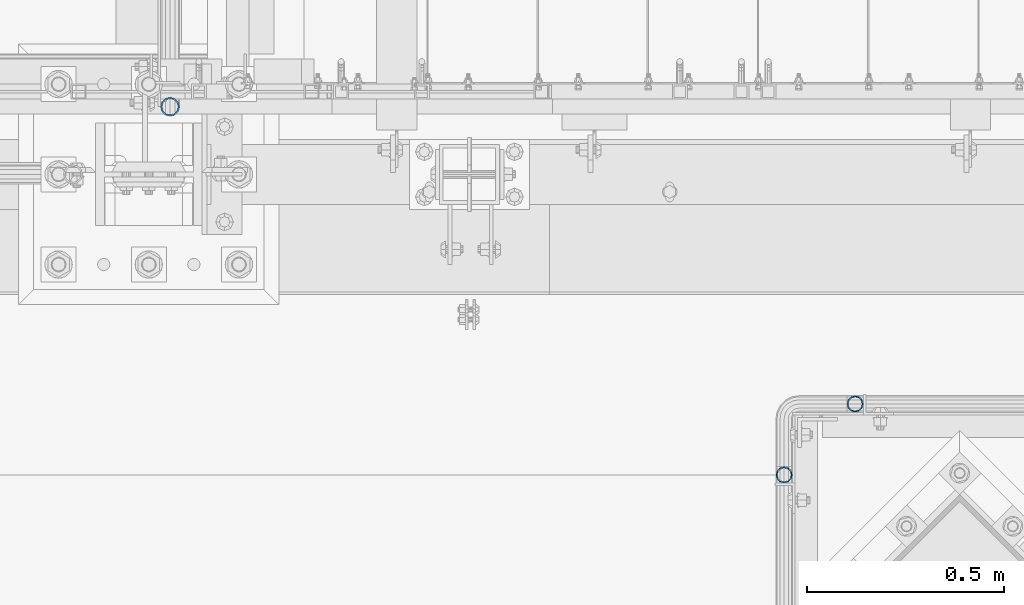
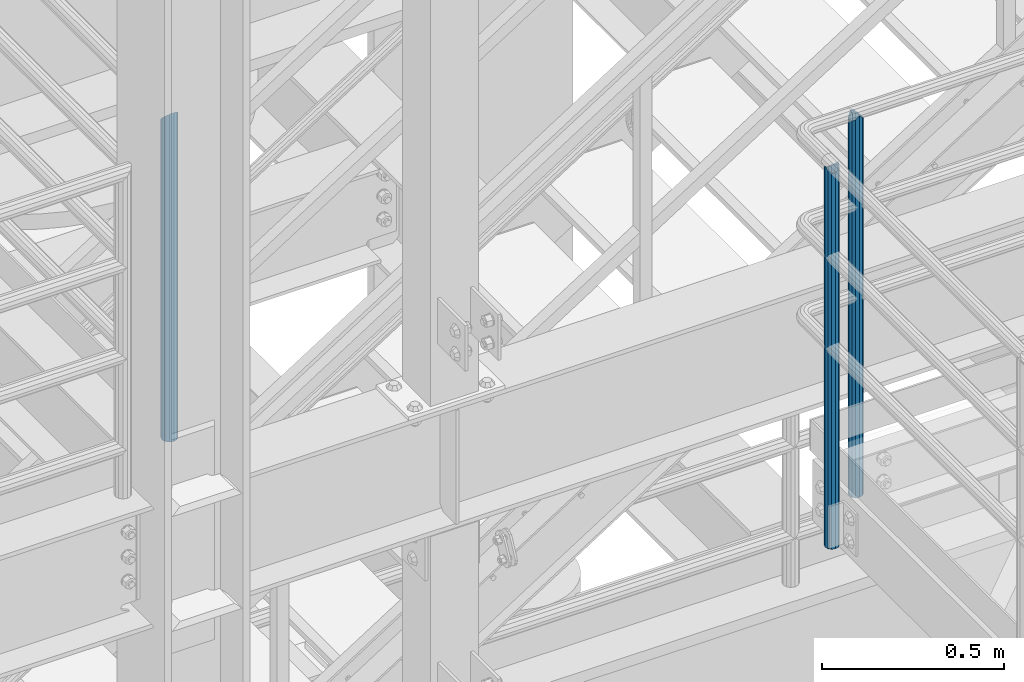
# One storey, part 571 of 1876: 3 columns, 3 elements without a shape of their own.
"""IFC2X3 building model written with IfcOpenShell, lengths in millimetres."""

import ifcopenshell
import ifcopenshell.guid

model = None  # the IFC model being written
_history = None  # IfcOwnerHistory: only IFC2X3 demands one
_inside = {}  # id of a spatial element -> (the spatial element, [elements in it])
_under = {}  # id of a project, library or spatial element -> (it, [spatial elements below it])
_declared = {}  # id of a project -> (the project, [libraries it declares])
_typed = {}  # id of a type object -> (the type object, [elements of that type])
_made_of = {}  # id of a material, layer set ... -> (it, [elements and type objects made of it])


def new_model(schema):
    """Start an empty IFC model of exactly this schema.

    Asked for "IFC4X3", IfcOpenShell would pick the latest addendum, in which some entities
    have other attributes; the version numbers below select the first issue.
    IFC2X3 requires an IfcOwnerHistory on every rooted entity: one is made here for all.
    """
    global model, _history
    if schema == "IFC4X3":
        model = ifcopenshell.file(schema_version=(4, 3, 0, 0))
    else:
        model = ifcopenshell.file(schema=schema)
    _inside.clear()
    _under.clear()
    _declared.clear()
    _typed.clear()
    _made_of.clear()
    _history = None
    if model.schema == "IFC2X3":
        org = make("IfcOrganization", Name="unknown")
        user = make(
            "IfcPersonAndOrganization",
            ThePerson=make("IfcPerson", FamilyName="unknown"),
            TheOrganization=org,
        )
        app = make(
            "IfcApplication",
            ApplicationDeveloper=org,
            Version="unknown",
            ApplicationFullName="unknown",
            ApplicationIdentifier="unknown",
        )
        _history = make(
            "IfcOwnerHistory",
            OwningUser=user,
            OwningApplication=app,
            ChangeAction="ADDED",
            CreationDate=0,
        )
    return model


def make(cls, **values):
    """One entity of the class cls with the attributes given. An attribute that is None is left unset."""
    return model.create_entity(
        cls, **{name: value for name, value in values.items() if value is not None}
    )


def rooted(cls, **values):
    """An entity with a GlobalId (a new one), such as an element, a storey or a relation."""
    return make(cls, GlobalId=ifcopenshell.guid.new(), OwnerHistory=_history, **values)


def si_unit(unit_type, name, prefix=None):
    """IfcSIUnit, for example si_unit("LENGTHUNIT", "METRE", prefix="MILLI")."""
    return make("IfcSIUnit", UnitType=unit_type, Prefix=prefix, Name=name)


def assignment(units):
    """IfcUnitAssignment: the units of a project."""
    return None if units is None else make("IfcUnitAssignment", Units=units)


def point(xyz):
    """IfcCartesianPoint."""
    return None if xyz is None else make("IfcCartesianPoint", Coordinates=xyz)


def direction(xyz):
    """IfcDirection."""
    return None if xyz is None else make("IfcDirection", DirectionRatios=xyz)


def frame(location, z_axis=None, x_axis=None):
    """IfcAxis2Placement3D, a coordinate frame: its origin and axes. An axis left out is left unset."""
    return make(
        "IfcAxis2Placement3D",
        Location=point(location),
        Axis=direction(z_axis),
        RefDirection=direction(x_axis),
    )


def origin_with_axes():
    """The frame at (0, 0, 0) with the z axis (0, 0, 1) and the x axis (1, 0, 0) written out."""
    return frame((0.0, 0.0, 0.0), z_axis=(0.0, 0.0, 1.0), x_axis=(1.0, 0.0, 0.0))


def place(relative_to, where):
    """IfcLocalPlacement: puts the frame where relative to a parent placement (None: the world)."""
    return make(
        "IfcLocalPlacement", PlacementRelTo=relative_to, RelativePlacement=where
    )


def context(
    kind, dimensions, precision=None, world=None, true_north=None, identifier=None
):
    """IfcGeometricRepresentationContext, for example the 3D "Model" context."""
    return make(
        "IfcGeometricRepresentationContext",
        ContextIdentifier=identifier,
        ContextType=kind,
        CoordinateSpaceDimension=dimensions,
        Precision=precision,
        WorldCoordinateSystem=world,
        TrueNorth=true_north,
    )


def subcontext(parent, identifier, kind, view, scale=None):
    """IfcGeometricRepresentationSubContext, for example "Body" below "Model"."""
    return make(
        "IfcGeometricRepresentationSubContext",
        ContextIdentifier=identifier,
        ContextType=kind,
        ParentContext=parent,
        TargetScale=scale,
        TargetView=view,
    )


def project(units=None, contexts=None):
    """IfcProject with its units and contexts."""
    return rooted(
        "IfcProject",
        Name="project",
        RepresentationContexts=contexts,
        UnitsInContext=assignment(units),
    )


def spatial(cls, under=None, at=None, **own):
    """A site, building, storey or space (cls), placed at a placement, below another one or the project."""
    s = rooted(cls, ObjectPlacement=at, **own)
    if under is not None:
        _under.setdefault(under.id(), (under, []))[1].append(s)
    return s


def faces_of(points, faces, orient=None, outer=None):
    """IfcFace entities. A face is a list of loops; a loop is a list of indices into points, from 0.

    orient and outer hold one flag for each loop. By default every Orientation is true, the
    first loop of a face is its IfcFaceOuterBound and the others are IfcFaceBound.
    """
    made = []
    for i, loops in enumerate(faces):
        bounds = []
        for j, loop in enumerate(loops):
            is_outer = j == 0 if outer is None else outer[i][j]
            bounds.append(
                make(
                    "IfcFaceOuterBound" if is_outer else "IfcFaceBound",
                    Bound=make("IfcPolyLoop", Polygon=[points[k] for k in loop]),
                    Orientation=True if orient is None else orient[i][j],
                )
            )
        made.append(make("IfcFace", Bounds=bounds))
    return made


def faceted_brep(points, faces, orient=None, outer=None, voids=None):
    """IfcFacetedBrep: a solid bounded by flat faces; with voids (closed shells), ...WithVoids."""
    shared = [point(p) for p in points]
    hull = make("IfcClosedShell", CfsFaces=faces_of(shared, faces, orient, outer))
    if voids is None:
        return make("IfcFacetedBrep", Outer=hull)
    return make(
        "IfcFacetedBrepWithVoids",
        Outer=hull,
        Voids=[
            make(cls, CfsFaces=faces_of(shared, fs, o, b)) for cls, fs, o, b in voids
        ],
    )


def shape(context_of_items, identifier, shape_type, items):
    """IfcShapeRepresentation: the items that make up one representation, for example the "Body"."""
    return make(
        "IfcShapeRepresentation",
        ContextOfItems=context_of_items,
        RepresentationIdentifier=identifier,
        RepresentationType=shape_type,
        Items=items,
    )


def material(Name=None, Category=None):
    """IfcMaterial."""
    return make("IfcMaterial", Name=Name, Category=Category)


def made_of(thing, what):
    """Note that an element or type object is made of a material, layer set ...; save() writes the relation."""
    if what is not None:
        _made_of.setdefault(what.id(), (what, []))[1].append(thing)
    return thing


def type_object(cls, material=None, **own):
    """A type object (cls), such as IfcWallType, which elements share."""
    return made_of(rooted(cls, **own), material)


def element(
    cls,
    number,
    at=None,
    inside=None,
    cuts=None,
    type_object=None,
    material=None,
    context=None,
    identifier="Body",
    shape_type=None,
    held_by="IfcProductDefinitionShape",
    body=None,
    shapes=None,
    **own,
):
    """One element of the class cls, such as IfcWall. Its Tag is "e" and its number.

    at: its placement. inside: the storey or other place that contains it. cuts: it is an
    opening in that element (IfcRelVoidsElement). A single representation is given by context,
    identifier, shape_type and body (its items); several are given by shapes. held_by: the class
    of the entity that holds the representations. save() writes the other relations.
    """
    e = rooted(cls, Tag="e%d" % number, ObjectPlacement=at, **own)
    if body is not None:
        shapes = [shape(context, identifier, shape_type, body)]
    if shapes is not None:
        e.Representation = make(held_by, Representations=shapes)
    if inside is not None:
        _inside.setdefault(inside.id(), (inside, []))[1].append(e)
    if cuts is not None:
        rooted(
            "IfcRelVoidsElement", RelatingBuildingElement=cuts, RelatedOpeningElement=e
        )
    if type_object is not None:
        _typed.setdefault(type_object.id(), (type_object, []))[1].append(e)
    return made_of(e, material)


def aggregate(whole, parts):
    """IfcRelAggregates: a whole, such as a stair, and the parts it consists of."""
    return rooted("IfcRelAggregates", RelatingObject=whole, RelatedObjects=parts)


def save(model, path):
    """Write the relations noted so far, then the file.

    IfcRelAggregates (storeys below a building ...), IfcRelContainedInSpatialStructure (elements
    in a storey), IfcRelDefinesByType, IfcRelAssociatesMaterial and IfcRelDeclares: one each for
    every whole, place, type object, material and project.
    """
    for whole, parts in _under.values():
        aggregate(whole, parts)
    for where, things in _inside.values():
        rooted(
            "IfcRelContainedInSpatialStructure",
            RelatedElements=things,
            RelatingStructure=where,
        )
    for kind, things in _typed.values():
        rooted("IfcRelDefinesByType", RelatedObjects=things, RelatingType=kind)
    for what, things in _made_of.values():
        rooted("IfcRelAssociatesMaterial", RelatedObjects=things, RelatingMaterial=what)
    for by, libraries in _declared.values():
        rooted("IfcRelDeclares", RelatingContext=by, RelatedDefinitions=libraries)
    model.write(path)


model = new_model("IFC2X3")

# Units and contexts
model_context = context("Model", 3, precision=1e-05, world=origin_with_axes())
body_context = subcontext(model_context, "Body", "Model", "MODEL_VIEW")
ifc_project = project(units=[si_unit("LENGTHUNIT", "METRE", prefix="MILLI"), si_unit("AREAUNIT", "SQUARE_METRE"), si_unit("VOLUMEUNIT", "CUBIC_METRE"), si_unit("MASSUNIT", "GRAM", prefix="KILO"), si_unit("TIMEUNIT", "SECOND"), si_unit("PLANEANGLEUNIT", "RADIAN"), si_unit("SOLIDANGLEUNIT", "STERADIAN"), si_unit("THERMODYNAMICTEMPERATUREUNIT", "DEGREE_CELSIUS"), si_unit("LUMINOUSINTENSITYUNIT", "LUMEN")], contexts=[model_context])

# Site, building, storey
site_placement = place(None, origin_with_axes())
site = spatial("IfcSite", under=ifc_project, at=site_placement, CompositionType="ELEMENT")
building_placement = place(site_placement, origin_with_axes())
building = spatial("IfcBuilding", under=site, at=building_placement, Name="Undefined", CompositionType="ELEMENT")
storey_placement = place(building_placement, origin_with_axes())
storey = spatial("IfcBuildingStorey", under=building, at=storey_placement, Name="Undefined", CompositionType="ELEMENT", Elevation=0.0)

# Assembly, column
assembly_1_placement = place(storey_placement, origin_with_axes())
assembly_1 = element("IfcElementAssembly", 1, at=assembly_1_placement, inside=storey, Name="HANDRAIL", AssemblyPlace="NOTDEFINED", PredefinedType="RIGID_FRAME")
ifc_material = material()
column_type_1 = type_object("IfcColumnType", Name="PIPE1-1/4STD", PredefinedType="NOTDEFINED")
column_1_placement = place(assembly_1_placement, frame((3517.90474593762, -7694.13240429563, 7813.675), z_axis=(0.0, 1.0, 0.0), x_axis=(0.0, 0.0, 1.0)))
column_1 = element("IfcColumn", 2, at=column_1_placement, type_object=column_type_1, material=ifc_material, Name="POST", ObjectType="PIPE1-1/4STD", context=body_context, shape_type="Brep", body=[
    faceted_brep([(1276.35, 0.0, -21.0820000000003), (1265.809, 10.5410000000002, -18.2575475625836), (1265.809, -10.5410000000002, -18.2575475625836), (1257.61603877328, 15.1779612267264, 8.76299999999992), (1255.268, 17.5259999999998, 0.0), (1255.268, 21.0820000000003, 0.0), (1258.09245243742, 18.2575475625836, 10.5410000000002), (1258.09245243742, 13.3999612267262, 10.5410000000002), (1258.09245243742, 13.3999612267262, -10.5410000000002), (1258.09245243742, 18.2575475625836, -10.5410000000002), (1257.61603877328, 15.1779612267264, -8.76299999999992), (1262.72937633681, 8.76299999999992, -15.1779612267255), (1265.07741511008, 0.0, -17.5259999999998), (1262.72937633681, -8.76299999999992, -15.1779612267255), (1258.09245243741, -13.3999612267244, -10.541000000002), (1258.09245243742, -18.2575475625836, -10.5409999999993), (1257.61602877145, -15.1779612267264, -8.76300000000083), (1255.268, -17.5259999999998, 0.0), (1255.268, -21.0820000000003, 0.0), (1257.61604877511, -15.1779612267264, 8.76300000000083), (1258.09245243741, -13.399961226728, 10.5409999999983), (1258.09245243742, -18.2575475625836, 10.5409999999993), (1276.35, 0.0, 21.0820000000003), (1265.809, -10.5410000000002, 18.2575475625836), (1265.809, 10.5410000000002, 18.2575475625836), (1262.72941366414, -8.76299999999992, 15.1779612267264), (1265.07745243742, 0.0, 17.5259999999998), (1262.72941366414, 8.76299999999992, 15.1779612267264), (0.0, -18.2575475625836, -10.5409999999993), (0.0, -10.5410000000002, -18.2575475625836), (-4.28826751885936e-09, 0.0, -21.0820000000003), (0.0, 10.5410000000002, -18.2575475625836), (0.0, 18.2575475625836, -10.5409999999993), (9.09494701772928e-13, 21.0820000000003, 0.0), (0.0, 18.2575475625836, 10.5409999999993), (0.0, 10.5410000000002, 18.2575475625836), (0.0, 0.0, 21.0820000000003), (0.0, -18.2575475625836, 10.5409999999993), (9.09494701772928e-13, -21.0820000000003, 0.0), (0.0, -10.5410000000002, 18.2575475625836), (0.0, -15.1779612267264, -8.76300000000083), (0.0, -8.76299999999992, -15.1779612267255), (0.0, 0.0, -17.5259999999998), (0.0, 8.76299999999992, -15.1779612267255), (0.0, 15.1779612267264, -8.76300000000083), (0.0, 17.5259999999998, 0.0), (0.0, 15.1779612267264, 8.76300000000083), (0.0, 8.76299999999992, 15.1779612267255), (0.0, 0.0, 17.5259999999998), (0.0, -8.76299999999992, 15.1779612267255), (0.0, -15.1779612267264, 8.76300000000083), (0.0, -17.5259999999998, 0.0)], [[[0, 1, 2]], [[3, 4, 5, 6, 7]], [[8, 9, 5, 4, 10]], [[2, 1, 9, 8, 11, 12, 13, 14, 15]], [[15, 14, 16, 17, 18]], [[18, 17, 19, 20, 21]], [[22, 23, 24]], [[21, 20, 25, 26, 27, 7, 6, 24, 23]], [[28, 29, 2, 15]], [[29, 30, 0, 2]], [[30, 31, 1, 0]], [[31, 32, 9, 1]], [[32, 33, 5, 9]], [[33, 34, 6, 5]], [[34, 35, 24, 6]], [[35, 36, 22, 24]], [[37, 38, 18, 21]], [[39, 37, 21, 23]], [[36, 39, 23, 22]], [[38, 28, 15, 18]], [[37, 39, 36, 35, 34, 33, 32, 31, 30, 29, 28, 38], [40, 41, 42, 43, 44, 45, 46, 47, 48, 49, 50, 51]], [[49, 48, 26, 25]], [[19, 50, 49, 25, 20]], [[51, 50, 19, 17]], [[40, 51, 17, 16]], [[41, 40, 16, 14, 13]], [[42, 41, 13, 12]], [[43, 42, 12, 11]], [[10, 44, 43, 11, 8]], [[45, 44, 10, 4]], [[46, 45, 4, 3]], [[47, 46, 3, 7, 27]], [[48, 47, 27, 26]]]),
])
aggregate(assembly_1, [column_1])

assembly_2_placement = place(storey_placement, origin_with_axes())
assembly_2 = element("IfcElementAssembly", 3, at=assembly_2_placement, inside=storey, Name="HANDRAIL", AssemblyPlace="NOTDEFINED", PredefinedType="RIGID_FRAME")
column_2_placement = place(assembly_2_placement, frame((3338.07274593762, -7873.96435546873, 7813.675), z_axis=(0.0, 1.0, 0.0), x_axis=(0.0, 0.0, 1.0)))
column_2 = element("IfcColumn", 4, at=column_2_placement, type_object=column_type_1, material=ifc_material, Name="POST", ObjectType="PIPE1-1/4STD", context=body_context, shape_type="Brep", body=[
    faceted_brep([(1258.09245243742, -10.5410000000002, 18.2575475625836), (1258.09245243742, -10.5410017746963, 13.3999594520301), (1257.61603823465, -8.76299999999992, 15.1779612267255), (1255.268, 0.0, 17.5259999999998), (1255.268, 0.0, 21.0820000000003), (1257.6160393119, 8.76299999999992, 15.1779612267255), (1258.09245243742, 10.5409982253032, 13.3999630014223), (1258.09245243742, 10.5410000000002, 18.2575475625836), (1276.35, 21.0820000000003, 0.0), (1265.809, 18.2575475625836, 10.5410000000002), (1265.809, 18.2575475625836, -10.5410000000002), (1262.72941482472, 15.1779612267264, 8.76300000000083), (1265.07745243742, 17.5259999999998, 0.0), (1262.72941250358, 15.1779612267264, -8.76300000000083), (1258.09245243742, 10.5410000000002, -13.3999612267253), (1258.09245243742, 10.5410000000002, -18.2575475625836), (1257.61603877328, 8.76299999999992, -15.1779612267255), (1255.268, 0.0, -17.5259999999998), (1255.268, 0.0, -21.0820000000003), (1258.09245243742, -10.5410000000002, -13.3999612267253), (1258.09245243742, -10.5410000000002, -18.2575475625836), (1257.61603877328, -8.76299999999992, -15.1779612267255), (1276.35000278283, -21.0820000000003, 0.0), (1265.809, -18.2575475625836, -10.5410000000002), (1265.809, -18.2575475625836, 10.5410000000002), (1262.72941366414, -15.1779612267264, -8.76300000000083), (1265.07745243742, -17.5259999999998, 0.0), (1262.72941366414, -15.1779612267264, 8.76300000000083), (0.0, -18.2575475625836, -10.5409999999993), (0.0, -10.5410000000002, -18.2575475625836), (-4.28826751885936e-09, 0.0, -21.0820000000003), (0.0, 10.5410000000002, -18.2575475625836), (0.0, 18.2575475625836, -10.5409999999993), (9.09494701772928e-13, 21.0820000000003, 0.0), (0.0, 18.2575475625836, 10.5409999999993), (0.0, 10.5410000000002, 18.2575475625836), (0.0, 0.0, 21.0820000000003), (0.0, -10.5410000000002, 18.2575475625836), (0.0, -18.2575475625836, 10.5409999999993), (9.09494701772928e-13, -21.0820000000003, 0.0), (0.0, -15.1779612267264, -8.76300000000083), (0.0, -8.76299999999992, -15.1779612267255), (0.0, 0.0, -17.5259999999998), (0.0, 8.76299999999992, -15.1779612267255), (0.0, 15.1779612267264, -8.76300000000083), (0.0, 17.5259999999998, 0.0), (0.0, 15.1779612267264, 8.76300000000083), (0.0, 8.76299999999992, 15.1779612267255), (0.0, 0.0, 17.5259999999998), (0.0, -8.76299999999992, 15.1779612267255), (0.0, -15.1779612267264, 8.76300000000083), (0.0, -17.5259999999998, 0.0)], [[[0, 1, 2, 3, 4]], [[4, 3, 5, 6, 7]], [[8, 9, 10]], [[7, 6, 11, 12, 13, 14, 15, 10, 9]], [[16, 17, 18, 15, 14]], [[19, 20, 18, 17, 21]], [[22, 23, 24]], [[24, 23, 20, 19, 25, 26, 27, 1, 0]], [[28, 29, 20, 23]], [[29, 30, 18, 20]], [[30, 31, 15, 18]], [[31, 32, 10, 15]], [[32, 33, 8, 10]], [[33, 34, 9, 8]], [[34, 35, 7, 9]], [[35, 36, 4, 7]], [[36, 37, 0, 4]], [[37, 38, 24, 0]], [[38, 39, 22, 24]], [[39, 28, 23, 22]], [[38, 37, 36, 35, 34, 33, 32, 31, 30, 29, 28, 39], [40, 41, 42, 43, 44, 45, 46, 47, 48, 49, 50, 51]], [[40, 51, 26, 25]], [[21, 41, 40, 25, 19]], [[42, 41, 21, 17]], [[43, 42, 17, 16]], [[44, 43, 16, 14, 13]], [[45, 44, 13, 12]], [[46, 45, 12, 11]], [[5, 47, 46, 11, 6]], [[48, 47, 5, 3]], [[49, 48, 3, 2]], [[50, 49, 2, 1, 27]], [[51, 50, 27, 26]]]),
])
aggregate(assembly_2, [column_2])

assembly_3_placement = place(storey_placement, origin_with_axes())
assembly_3 = element("IfcElementAssembly", 5, at=assembly_3_placement, inside=storey, Name="RAIL", AssemblyPlace="NOTDEFINED", PredefinedType="RIGID_FRAME")
column_type_2 = type_object("IfcColumnType", Name="PIPE1-1/2SCH40", PredefinedType="NOTDEFINED")
column_3_placement = place(assembly_3_placement, frame((1781.175, -6940.55, 8153.4), z_axis=(0.0, 1.0, 0.0), x_axis=(0.0, 0.0, 1.0)))
column_3 = element("IfcColumn", 6, at=column_3_placement, type_object=column_type_2, material=ifc_material, Name="POST", ObjectType="PIPE1-1/2SCH40", context=body_context, shape_type="Brep", body=[
    faceted_brep([(0.0, -20.4469999999999, 0.0), (0.0, -17.7076214311803, 10.2235000000001), (1066.1015, -17.7076214311803, 10.2235000000001), (1076.325, -20.4469999999999, 0.0), (0.0, -10.2235000000001, 17.7076214311801), (1058.61737856882, -10.2235000000001, 17.7076214311801), (-1.45519152283669e-11, 0.0, 20.4470000000001), (1055.878, 0.0, 20.4470000000001), (0.0, 10.2235000000001, 17.7076214311801), (1058.61737856882, 10.2235000000001, 17.7076214311801), (0.0, 17.7076214311803, 10.2235000000001), (1066.1015, 17.7076214311803, 10.2235000000001), (0.0, 20.4469999999999, 0.0), (1076.325, 20.4469999999999, 0.0), (0.0, 17.7076214311803, -10.2235000000001), (1086.5485, 17.7076214311803, -10.2235000000001), (0.0, 10.2235000000001, -17.7076214311801), (1094.03262143118, 10.2235000000001, -17.7076214311801), (-1.45519152283669e-11, 0.0, -20.4470000000001), (1096.772, 0.0, -20.4470000000001), (0.0, -10.2235000000001, -17.7076214311801), (1094.03262143118, -10.2235000000001, -17.7076214311801), (0.0, -17.7076214311803, -10.2235000000001), (1086.5485, -17.7076214311803, -10.2235000000001), (0.0, -24.1299999999992, 0.0), (0.0, -20.8971929933184, -12.0649999999996), (1088.39, -20.8971929933184, -12.0649999999996), (1076.325, -24.1300000000001, 0.0), (0.0, -12.0650000000001, -20.8971929933186), (1097.22219299332, -12.0650000000001, -20.8971929933186), (-1.45519152283669e-11, 0.0, -24.130000000001), (1100.455, 0.0, -24.1300000000001), (0.0, 12.0650000000001, -20.8971929933186), (1097.22219299332, 12.0650000000001, -20.8971929933186), (0.0, 20.8971929933184, -12.0649999999996), (1088.39, 20.8971929933184, -12.0649999999996), (0.0, 24.1299999999992, 0.0), (1076.325, 24.1300000000001, 0.0), (0.0, 20.8971929933184, 12.0649999999996), (1064.26, 20.8971929933184, 12.0649999999996), (0.0, 12.0650000000001, 20.8971929933186), (1055.42780700668, 12.0650000000001, 20.8971929933186), (-1.45519152283669e-11, 0.0, 24.130000000001), (1052.195, 0.0, 24.1300000000001), (0.0, -12.0650000000001, 20.8971929933186), (1055.42780700668, -12.0650000000001, 20.8971929933186), (0.0, -20.8971929933184, 12.0649999999996), (1064.26, -20.8971929933184, 12.0649999999996)], [[[0, 1, 2, 3]], [[1, 4, 5, 2]], [[4, 6, 7, 5]], [[6, 8, 9, 7]], [[8, 10, 11, 9]], [[10, 12, 13, 11]], [[12, 14, 15, 13]], [[14, 16, 17, 15]], [[16, 18, 19, 17]], [[18, 20, 21, 19]], [[20, 22, 23, 21]], [[22, 0, 3, 23]], [[24, 25, 26, 27]], [[25, 28, 29, 26]], [[28, 30, 31, 29]], [[30, 32, 33, 31]], [[32, 34, 35, 33]], [[34, 36, 37, 35]], [[36, 38, 39, 37]], [[38, 40, 41, 39]], [[40, 42, 43, 41]], [[42, 44, 45, 43]], [[44, 46, 47, 45]], [[46, 24, 27, 47]], [[29, 31, 33, 35, 37, 39, 41, 43, 45, 47, 27, 26], [5, 7, 9, 11, 13, 15, 17, 19, 21, 23, 3, 2]], [[46, 44, 42, 40, 38, 36, 34, 32, 30, 28, 25, 24], [22, 20, 18, 16, 14, 12, 10, 8, 6, 4, 1, 0]]]),
])
aggregate(assembly_3, [column_3])

save(model, "model.ifc")
